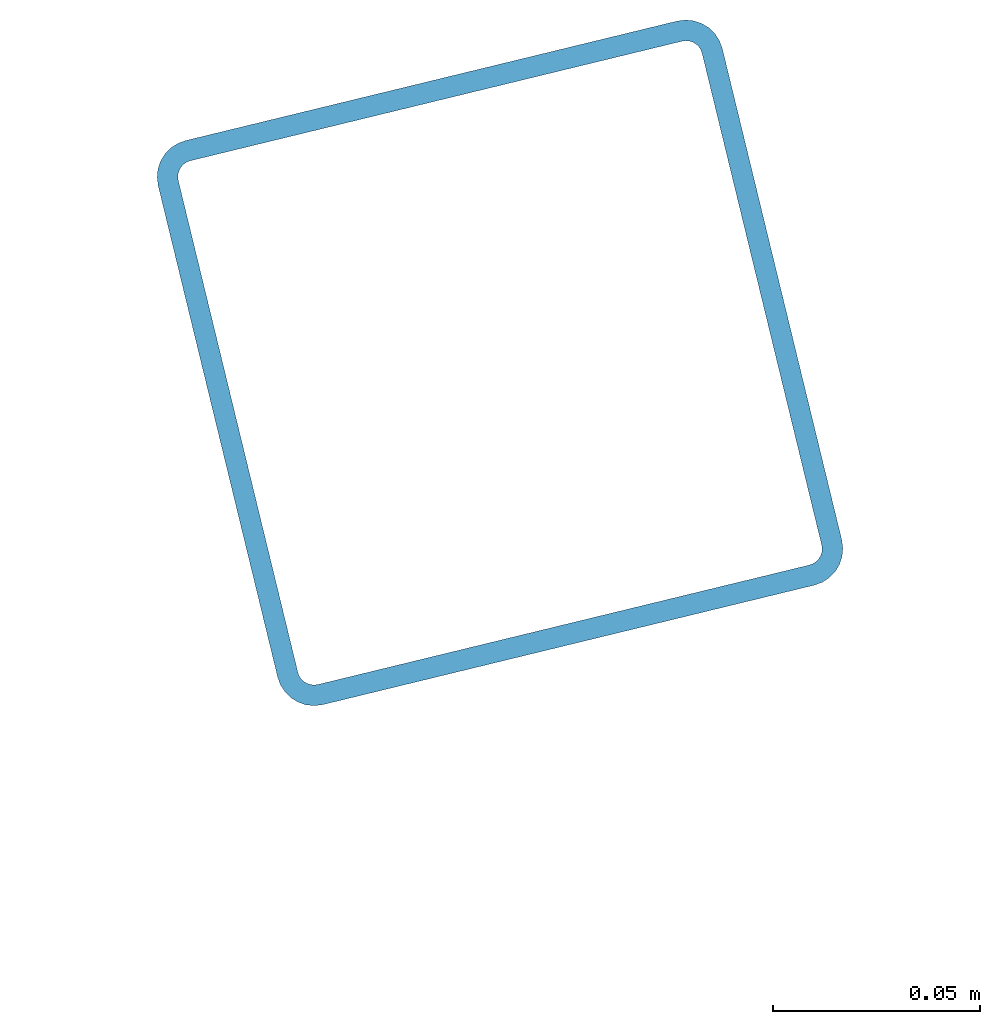
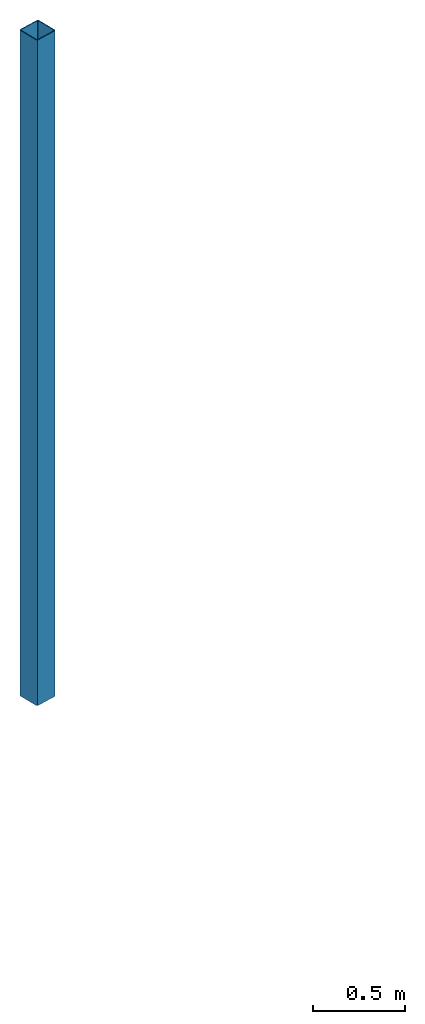
# One storey, part 6 of 10: 1 beam.
"""IFC2X3 building model written with IfcOpenShell, lengths in millimetres."""

from ifc_helpers import new_model, entity, si_unit, converted_unit, derived_unit, direction, frame, frame_2d, origin, place, context, subcontext, project, spatial, polyline, circle_curve, parameter, trimmed, segment, composite_curve, outline, extrude, material, type_object, element, save


model = new_model("IFC2X3")

# Units and contexts
model_context = context("Model", 3, precision=0.01, world=origin(), true_north=direction((6.12303176911189e-17, 1.0)))
body_context = subcontext(model_context, "Body", "Model", "MODEL_VIEW")
ifc_project = project(units=[si_unit("LENGTHUNIT", "METRE", prefix="MILLI"), si_unit("AREAUNIT", "SQUARE_METRE"), si_unit("VOLUMEUNIT", "CUBIC_METRE"), converted_unit("PLANEANGLEUNIT", "DEGREE", entity("IfcRatioMeasure", 0.0174532925199433), si_unit("PLANEANGLEUNIT", "RADIAN"), dimensions=[0, 0, 0, 0, 0, 0, 0]), si_unit("MASSUNIT", "GRAM", prefix="KILO"), derived_unit("MASSDENSITYUNIT", [(si_unit("MASSUNIT", "GRAM", prefix="KILO"), 1), (si_unit("LENGTHUNIT", "METRE"), -3)]), derived_unit("MOMENTOFINERTIAUNIT", [(si_unit("LENGTHUNIT", "METRE"), 4)]), si_unit("TIMEUNIT", "SECOND"), si_unit("FREQUENCYUNIT", "HERTZ"), si_unit("THERMODYNAMICTEMPERATUREUNIT", "DEGREE_CELSIUS"), derived_unit("THERMALTRANSMITTANCEUNIT", [(si_unit("MASSUNIT", "GRAM", prefix="KILO"), 1), (si_unit("THERMODYNAMICTEMPERATUREUNIT", "KELVIN"), -1), (si_unit("TIMEUNIT", "SECOND"), -3)]), derived_unit("VOLUMETRICFLOWRATEUNIT", [(si_unit("LENGTHUNIT", "METRE"), 3), (si_unit("TIMEUNIT", "SECOND"), -1)]), derived_unit("MASSFLOWRATEUNIT", [(si_unit("MASSUNIT", "GRAM", prefix="KILO"), 1), (si_unit("TIMEUNIT", "SECOND"), -1)]), derived_unit("ROTATIONALFREQUENCYUNIT", [(si_unit("TIMEUNIT", "SECOND"), -1)]), si_unit("ELECTRICCURRENTUNIT", "AMPERE"), si_unit("ELECTRICVOLTAGEUNIT", "VOLT"), si_unit("POWERUNIT", "WATT"), si_unit("FORCEUNIT", "NEWTON", prefix="KILO"), si_unit("ILLUMINANCEUNIT", "LUX"), si_unit("LUMINOUSFLUXUNIT", "LUMEN"), si_unit("LUMINOUSINTENSITYUNIT", "CANDELA"), derived_unit("USERDEFINED", [(si_unit("MASSUNIT", "GRAM", prefix="KILO"), -1), (si_unit("LENGTHUNIT", "METRE"), -2), (si_unit("TIMEUNIT", "SECOND"), 3), (si_unit("LUMINOUSFLUXUNIT", "LUMEN"), 1)]), derived_unit("LINEARVELOCITYUNIT", [(si_unit("LENGTHUNIT", "METRE"), 1), (si_unit("TIMEUNIT", "SECOND"), -1)]), si_unit("PRESSUREUNIT", "PASCAL"), derived_unit("USERDEFINED", [(si_unit("LENGTHUNIT", "METRE"), -2), (si_unit("MASSUNIT", "GRAM", prefix="KILO"), 1), (si_unit("TIMEUNIT", "SECOND"), -2)]), derived_unit("LINEARFORCEUNIT", [(si_unit("MASSUNIT", "GRAM", prefix="KILO"), 1), (si_unit("LENGTHUNIT", "METRE"), 1), (si_unit("TIMEUNIT", "SECOND"), -2), (si_unit("LENGTHUNIT", "METRE"), -1)]), derived_unit("PLANARFORCEUNIT", [(si_unit("MASSUNIT", "GRAM", prefix="KILO"), 1), (si_unit("LENGTHUNIT", "METRE"), 1), (si_unit("TIMEUNIT", "SECOND"), -2), (si_unit("LENGTHUNIT", "METRE"), -2)])], contexts=[model_context])

# Site, building, storey
site_placement = place(None, frame((19171.75, -72498.58, 0.0), z_axis=(0.0, 0.0, 1.0), x_axis=(0.971695960795463, 0.236234967296933, 0.0)))
site = spatial("IfcSite", under=ifc_project, at=site_placement, CompositionType="ELEMENT")
building_placement = place(site_placement, origin())
building = spatial("IfcBuilding", under=site, at=building_placement, CompositionType="ELEMENT")
storey_placement = place(building_placement, origin())
storey = spatial("IfcBuildingStorey", under=building, at=storey_placement, Name="01", CompositionType="ELEMENT", Elevation=0.0)

# Beam
ifc_material = material()
beam_type = type_object("IfcBeamType", Name="ADSK_ 140x140x5", PredefinedType="NOTDEFINED")
beam_placement = place(storey_placement, frame((11328.4, 20028.4, -180.0), z_axis=(1.0, 0.0, 0.0), x_axis=(0.0, 0.0, -1.0)))
element("IfcBeam", 1, at=beam_placement, inside=storey, type_object=beam_type, material=ifc_material, Name="ADSK_ 140x140x5", ObjectType="ADSK_ 140x140x5", context=body_context, shape_type="SweptSolid", body=[
    extrude(outline(composite_curve([segment(trimmed(circle_curve(frame_2d((61.0, -61.0), x_axis=(1.0, 0.0)), 8.99999999999772), [parameter(269.999999999999)], [parameter(1.27222187258541e-12)], True, "PARAMETER"), True, "CONTINUOUS"), segment(polyline([(70.0, -61.0), (70.0, 61.0)]), True, "CONTINUOUS"), segment(trimmed(circle_curve(frame_2d((61.0, 61.0), x_axis=(1.0, 0.0)), 8.99999999999909), [parameter(1.27222187258541e-12)], [parameter(90.0000000000001)], True, "PARAMETER"), True, "CONTINUOUS"), segment(polyline([(61.0, 70.0), (-61.0, 70.0)]), True, "CONTINUOUS"), segment(trimmed(circle_curve(frame_2d((-61.0, 61.0), x_axis=(1.0, 0.0)), 8.99999999999999), [parameter(90.0000000000001)], [parameter(180.0)], True, "PARAMETER"), True, "CONTINUOUS"), segment(polyline([(-70.0, 61.0), (-70.0, -61.0)]), True, "CONTINUOUS"), segment(trimmed(circle_curve(frame_2d((-61.0, -61.0), x_axis=(1.0, 0.0)), 8.99999999999937), [parameter(180.0)], [parameter(269.999999999998)], True, "PARAMETER"), True, "CONTINUOUS"), segment(polyline([(-61.0, -70.0), (61.0, -70.0)]), True, "CONTINUOUS")], self_intersect=False), holes=[composite_curve([segment(polyline([(61.0, -65.0), (-61.0, -65.0)]), True, "CONTINUOUS"), segment(trimmed(circle_curve(frame_2d((-61.0, -61.0), x_axis=(1.0, 0.0)), 3.99999999999972), [parameter(180.0)], [parameter(270.0)], True, "PARAMETER"), False, "CONTINUOUS"), segment(polyline([(-65.0, -61.0), (-65.0, 61.0)]), True, "CONTINUOUS"), segment(trimmed(circle_curve(frame_2d((-61.0, 61.0), x_axis=(1.0, 0.0)), 3.99999999999971), [parameter(90.0000000000003)], [parameter(180.0)], True, "PARAMETER"), False, "CONTINUOUS"), segment(polyline([(-61.0, 65.0), (61.0, 65.0)]), True, "CONTINUOUS"), segment(trimmed(circle_curve(frame_2d((61.0, 61.0), x_axis=(1.0, 0.0)), 3.9999999999997), [parameter(3.56222124323914e-13)], [parameter(90.0000000000004)], True, "PARAMETER"), False, "CONTINUOUS"), segment(polyline([(65.0, 61.0), (65.0, -61.0)]), True, "CONTINUOUS"), segment(trimmed(circle_curve(frame_2d((61.0, -61.0), x_axis=(1.0, 0.0)), 4.00000000000034), [parameter(270.0)], [parameter(5.08888749034163e-13)], True, "PARAMETER"), False, "CONTINUOUS")], self_intersect=False)]), frame((-4419.54, 71.6, 71.6), z_axis=(1.0, 0.0, 0.0), x_axis=(0.0, 0.0, 1.0)), (0.0, 0.0, 1.0), 4419.5405845398),
])

save(model, "model.ifc")
